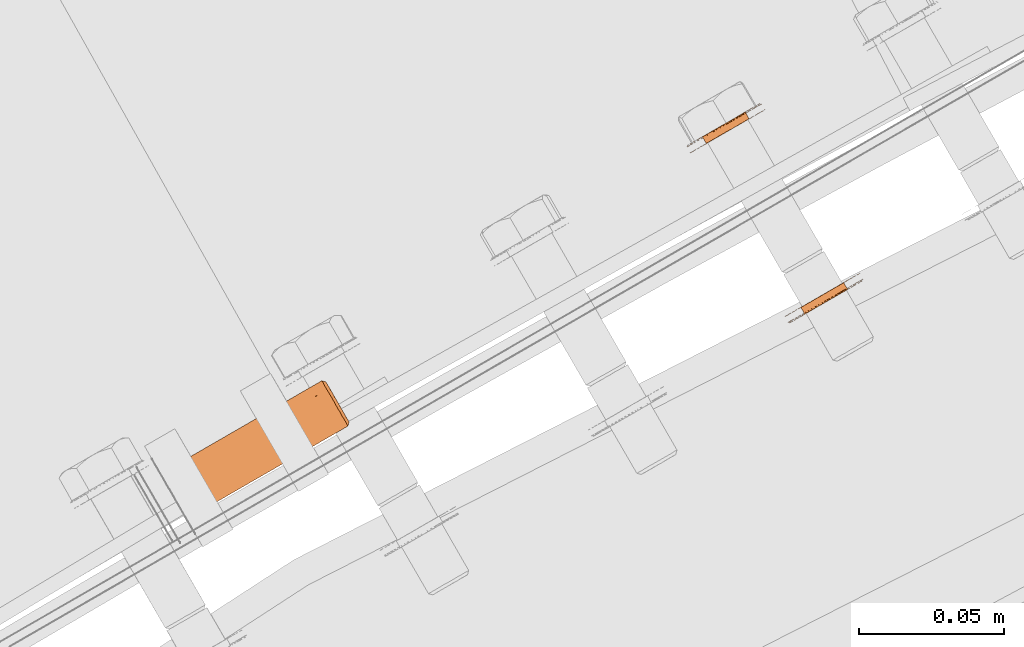
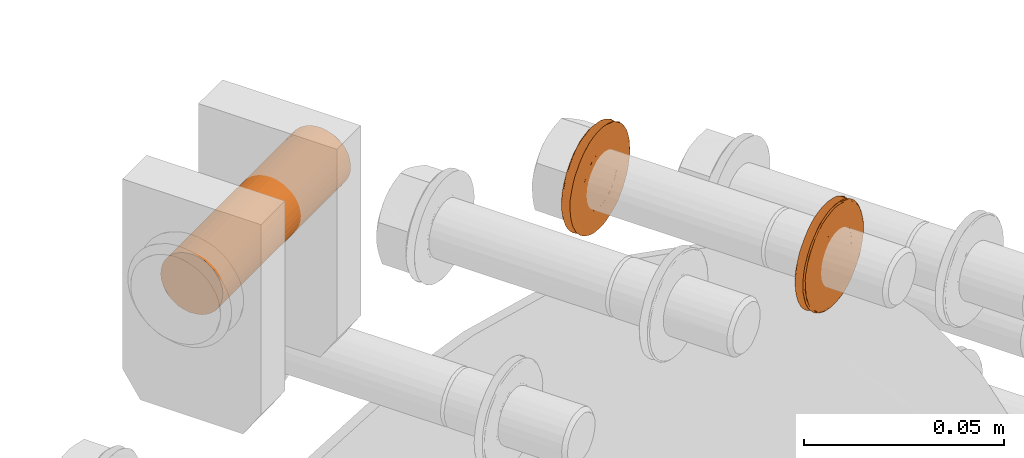
# One storey, part 118 of 126: 3 proxies.
"""IFC2X3 building model written with IfcOpenShell, lengths in millimetres."""

import ifcopenshell
import ifcopenshell.guid

model = None  # the IFC model being written
_history = None  # IfcOwnerHistory: only IFC2X3 demands one
_inside = {}  # id of a spatial element -> (the spatial element, [elements in it])
_under = {}  # id of a project, library or spatial element -> (it, [spatial elements below it])
_declared = {}  # id of a project -> (the project, [libraries it declares])
_typed = {}  # id of a type object -> (the type object, [elements of that type])
_made_of = {}  # id of a material, layer set ... -> (it, [elements and type objects made of it])


def new_model(schema):
    """Start an empty IFC model of exactly this schema.

    Asked for "IFC4X3", IfcOpenShell would pick the latest addendum, in which some entities
    have other attributes; the version numbers below select the first issue.
    IFC2X3 requires an IfcOwnerHistory on every rooted entity: one is made here for all.
    """
    global model, _history
    if schema == "IFC4X3":
        model = ifcopenshell.file(schema_version=(4, 3, 0, 0))
    else:
        model = ifcopenshell.file(schema=schema)
    _inside.clear()
    _under.clear()
    _declared.clear()
    _typed.clear()
    _made_of.clear()
    _history = None
    if model.schema == "IFC2X3":
        org = make("IfcOrganization", Name="unknown")
        user = make(
            "IfcPersonAndOrganization",
            ThePerson=make("IfcPerson", FamilyName="unknown"),
            TheOrganization=org,
        )
        app = make(
            "IfcApplication",
            ApplicationDeveloper=org,
            Version="unknown",
            ApplicationFullName="unknown",
            ApplicationIdentifier="unknown",
        )
        _history = make(
            "IfcOwnerHistory",
            OwningUser=user,
            OwningApplication=app,
            ChangeAction="ADDED",
            CreationDate=0,
        )
    return model


def make(cls, **values):
    """One entity of the class cls with the attributes given. An attribute that is None is left unset."""
    return model.create_entity(
        cls, **{name: value for name, value in values.items() if value is not None}
    )


def rooted(cls, **values):
    """An entity with a GlobalId (a new one), such as an element, a storey or a relation."""
    return make(cls, GlobalId=ifcopenshell.guid.new(), OwnerHistory=_history, **values)


def si_unit(unit_type, name, prefix=None):
    """IfcSIUnit, for example si_unit("LENGTHUNIT", "METRE", prefix="MILLI")."""
    return make("IfcSIUnit", UnitType=unit_type, Prefix=prefix, Name=name)


def assignment(units):
    """IfcUnitAssignment: the units of a project."""
    return None if units is None else make("IfcUnitAssignment", Units=units)


def point(xyz):
    """IfcCartesianPoint."""
    return None if xyz is None else make("IfcCartesianPoint", Coordinates=xyz)


def direction(xyz):
    """IfcDirection."""
    return None if xyz is None else make("IfcDirection", DirectionRatios=xyz)


def frame(location, z_axis=None, x_axis=None):
    """IfcAxis2Placement3D, a coordinate frame: its origin and axes. An axis left out is left unset."""
    return make(
        "IfcAxis2Placement3D",
        Location=point(location),
        Axis=direction(z_axis),
        RefDirection=direction(x_axis),
    )


def origin():
    """The frame at (0, 0, 0) with its axes left unset."""
    return frame((0.0, 0.0, 0.0))


def origin_with_axes():
    """The frame at (0, 0, 0) with the z axis (0, 0, 1) and the x axis (1, 0, 0) written out."""
    return frame((0.0, 0.0, 0.0), z_axis=(0.0, 0.0, 1.0), x_axis=(1.0, 0.0, 0.0))


def place(relative_to, where):
    """IfcLocalPlacement: puts the frame where relative to a parent placement (None: the world)."""
    return make(
        "IfcLocalPlacement", PlacementRelTo=relative_to, RelativePlacement=where
    )


def context(
    kind, dimensions, precision=None, world=None, true_north=None, identifier=None
):
    """IfcGeometricRepresentationContext, for example the 3D "Model" context."""
    return make(
        "IfcGeometricRepresentationContext",
        ContextIdentifier=identifier,
        ContextType=kind,
        CoordinateSpaceDimension=dimensions,
        Precision=precision,
        WorldCoordinateSystem=world,
        TrueNorth=true_north,
    )


def project(units=None, contexts=None):
    """IfcProject with its units and contexts."""
    return rooted(
        "IfcProject",
        Name="project",
        RepresentationContexts=contexts,
        UnitsInContext=assignment(units),
    )


def spatial(cls, under=None, at=None, **own):
    """A site, building, storey or space (cls), placed at a placement, below another one or the project."""
    s = rooted(cls, ObjectPlacement=at, **own)
    if under is not None:
        _under.setdefault(under.id(), (under, []))[1].append(s)
    return s


def faces_of(points, faces, orient=None, outer=None):
    """IfcFace entities. A face is a list of loops; a loop is a list of indices into points, from 0.

    orient and outer hold one flag for each loop. By default every Orientation is true, the
    first loop of a face is its IfcFaceOuterBound and the others are IfcFaceBound.
    """
    made = []
    for i, loops in enumerate(faces):
        bounds = []
        for j, loop in enumerate(loops):
            is_outer = j == 0 if outer is None else outer[i][j]
            bounds.append(
                make(
                    "IfcFaceOuterBound" if is_outer else "IfcFaceBound",
                    Bound=make("IfcPolyLoop", Polygon=[points[k] for k in loop]),
                    Orientation=True if orient is None else orient[i][j],
                )
            )
        made.append(make("IfcFace", Bounds=bounds))
    return made


def faceted_brep(points, faces, orient=None, outer=None, voids=None):
    """IfcFacetedBrep: a solid bounded by flat faces; with voids (closed shells), ...WithVoids."""
    shared = [point(p) for p in points]
    hull = make("IfcClosedShell", CfsFaces=faces_of(shared, faces, orient, outer))
    if voids is None:
        return make("IfcFacetedBrep", Outer=hull)
    return make(
        "IfcFacetedBrepWithVoids",
        Outer=hull,
        Voids=[
            make(cls, CfsFaces=faces_of(shared, fs, o, b)) for cls, fs, o, b in voids
        ],
    )


def shape(context_of_items, identifier, shape_type, items):
    """IfcShapeRepresentation: the items that make up one representation, for example the "Body"."""
    return make(
        "IfcShapeRepresentation",
        ContextOfItems=context_of_items,
        RepresentationIdentifier=identifier,
        RepresentationType=shape_type,
        Items=items,
    )


def material(Name=None, Category=None):
    """IfcMaterial."""
    return make("IfcMaterial", Name=Name, Category=Category)


def made_of(thing, what):
    """Note that an element or type object is made of a material, layer set ...; save() writes the relation."""
    if what is not None:
        _made_of.setdefault(what.id(), (what, []))[1].append(thing)
    return thing


def element(
    cls,
    number,
    at=None,
    inside=None,
    cuts=None,
    type_object=None,
    material=None,
    context=None,
    identifier="Body",
    shape_type=None,
    held_by="IfcProductDefinitionShape",
    body=None,
    shapes=None,
    **own,
):
    """One element of the class cls, such as IfcWall. Its Tag is "e" and its number.

    at: its placement. inside: the storey or other place that contains it. cuts: it is an
    opening in that element (IfcRelVoidsElement). A single representation is given by context,
    identifier, shape_type and body (its items); several are given by shapes. held_by: the class
    of the entity that holds the representations. save() writes the other relations.
    """
    e = rooted(cls, Tag="e%d" % number, ObjectPlacement=at, **own)
    if body is not None:
        shapes = [shape(context, identifier, shape_type, body)]
    if shapes is not None:
        e.Representation = make(held_by, Representations=shapes)
    if inside is not None:
        _inside.setdefault(inside.id(), (inside, []))[1].append(e)
    if cuts is not None:
        rooted(
            "IfcRelVoidsElement", RelatingBuildingElement=cuts, RelatedOpeningElement=e
        )
    if type_object is not None:
        _typed.setdefault(type_object.id(), (type_object, []))[1].append(e)
    return made_of(e, material)


def aggregate(whole, parts):
    """IfcRelAggregates: a whole, such as a stair, and the parts it consists of."""
    return rooted("IfcRelAggregates", RelatingObject=whole, RelatedObjects=parts)


def save(model, path):
    """Write the relations noted so far, then the file.

    IfcRelAggregates (storeys below a building ...), IfcRelContainedInSpatialStructure (elements
    in a storey), IfcRelDefinesByType, IfcRelAssociatesMaterial and IfcRelDeclares: one each for
    every whole, place, type object, material and project.
    """
    for whole, parts in _under.values():
        aggregate(whole, parts)
    for where, things in _inside.values():
        rooted(
            "IfcRelContainedInSpatialStructure",
            RelatedElements=things,
            RelatingStructure=where,
        )
    for kind, things in _typed.values():
        rooted("IfcRelDefinesByType", RelatedObjects=things, RelatingType=kind)
    for what, things in _made_of.values():
        rooted("IfcRelAssociatesMaterial", RelatedObjects=things, RelatingMaterial=what)
    for by, libraries in _declared.values():
        rooted("IfcRelDeclares", RelatingContext=by, RelatedDefinitions=libraries)
    model.write(path)


model = new_model("IFC2X3")

# Units and contexts
context_of_model_1 = context(None, 3, precision=0.1, world=origin())
context_of_model_2 = context(None, 3, precision=0.1, world=origin())
ifc_project = project(units=[si_unit("LENGTHUNIT", "METRE", prefix="MILLI"), si_unit("AREAUNIT", "SQUARE_METRE", prefix="CENTI"), si_unit("VOLUMEUNIT", "CUBIC_METRE", prefix="CENTI"), si_unit("MASSUNIT", "GRAM", prefix="KILO")], contexts=[context_of_model_1, context_of_model_2])

# Site, building, storey
site_placement = place(None, origin_with_axes())
site = spatial("IfcSite", under=ifc_project, at=site_placement, CompositionType="ELEMENT")
building_placement = place(site_placement, origin_with_axes())
building = spatial("IfcBuilding", under=site, at=building_placement, CompositionType="ELEMENT")
storey_placement = place(building_placement, origin_with_axes())
storey = spatial("IfcBuildingStorey", under=building, at=storey_placement, CompositionType="ELEMENT")

# Proxies
ifc_material = material(Name="STAHL")
proxy_1_placement = place(storey_placement, origin_with_axes())
element("IfcBuildingElementProxy", 1, at=proxy_1_placement, inside=storey, material=ifc_material, Name="profile", context=context_of_model_2, shape_type="Brep", body=[
    faceted_brep([(4189.1, 15005.2, 1270.8), (4187.8, 15007.6, 1270.8), (4187.3, 15007.3, 1271.8), (4188.6, 15004.9, 1271.8), (4189.7, 15005.6, 1269.8), (4188.4, 15007.9, 1269.8), (4190.5, 15006.0, 1268.9), (4189.1, 15008.3, 1268.9), (4191.3, 15006.5, 1268.2), (4190.0, 15008.8, 1268.2), (4198.6, 15010.7, 1282.9), (4197.2, 15013.0, 1282.9), (4198.1, 15013.5, 1282.3), (4199.5, 15011.2, 1282.3), (4197.6, 15010.1, 1283.3), (4196.2, 15012.4, 1283.3), (4196.6, 15009.5, 1283.6), (4195.2, 15011.9, 1283.6), (4195.5, 15008.9, 1283.7), (4194.2, 15011.2, 1283.7), (4194.5, 15008.3, 1283.7), (4193.1, 15010.6, 1283.7), (4193.4, 15007.7, 1283.4), (4192.1, 15010.0, 1283.4), (4192.5, 15007.1, 1283.0), (4191.1, 15009.5, 1283.0), (4191.5, 15006.6, 1282.5), (4190.2, 15008.9, 1282.5), (4190.7, 15006.1, 1281.7), (4189.3, 15008.4, 1281.7), (4189.9, 15005.7, 1280.9), (4188.6, 15008.0, 1280.9), (4189.3, 15005.3, 1279.9), (4187.9, 15007.6, 1279.9), (4188.8, 15005.0, 1278.9), (4187.4, 15007.3, 1278.9), (4188.4, 15004.8, 1277.8), (4187.0, 15007.1, 1277.8), (4188.1, 15004.6, 1276.6), (4186.8, 15007.0, 1276.6), (4188.0, 15004.6, 1275.4), (4186.7, 15006.9, 1275.4), (4188.1, 15004.6, 1274.2), (4186.7, 15007.0, 1274.2), (4188.3, 15004.7, 1273.0), (4186.9, 15007.1, 1273.0), (4182.2, 15001.7, 1274.6), (4182.2, 15001.7, 1276.2), (4182.4, 15001.8, 1277.8), (4182.7, 15002.0, 1279.3), (4183.1, 15002.2, 1280.8), (4183.7, 15002.5, 1282.2), (4184.4, 15002.9, 1283.6), (4185.2, 15003.4, 1284.8), (4186.1, 15003.9, 1286.0), (4187.2, 15004.5, 1287.0), (4188.3, 15005.2, 1287.9), (4189.4, 15005.9, 1288.7), (4190.7, 15006.6, 1289.3), (4192.0, 15007.3, 1289.8), (4193.3, 15008.1, 1290.1), (4194.7, 15008.9, 1290.2), (4196.0, 15009.7, 1290.2), (4197.4, 15010.4, 1290.0), (4198.7, 15011.2, 1289.7), (4200.0, 15012.0, 1289.2), (4201.2, 15012.7, 1288.5), (4202.4, 15013.3, 1287.7), (4203.5, 15014.0, 1286.8), (4204.5, 15014.6, 1285.7), (4205.4, 15015.1, 1284.5), (4206.2, 15015.5, 1283.2), (4206.8, 15015.9, 1281.9), (4207.4, 15016.2, 1280.4), (4207.8, 15016.4, 1278.9), (4208.0, 15016.6, 1277.4), (4208.2, 15016.7, 1275.8), (4208.2, 15016.7, 1274.2), (4208.0, 15016.6, 1272.7), (4207.7, 15016.4, 1271.2), (4207.3, 15016.1, 1269.7), (4206.7, 15015.8, 1268.2), (4206.0, 15015.4, 1266.9), (4205.2, 15014.9, 1265.6), (4204.3, 15014.4, 1264.5), (4203.2, 15013.8, 1263.4), (4202.1, 15013.2, 1262.5), (4200.9, 15012.5, 1261.8), (4199.7, 15011.8, 1261.2), (4198.4, 15011.0, 1260.7), (4197.1, 15010.3, 1260.4), (4195.7, 15009.5, 1260.2), (4194.3, 15008.7, 1260.3), (4193.0, 15007.9, 1260.4), (4191.7, 15007.1, 1260.8), (4190.4, 15006.4, 1261.3), (4189.1, 15005.7, 1262.0), (4188.0, 15005.0, 1262.8), (4186.9, 15004.4, 1263.7), (4185.9, 15003.8, 1264.8), (4185.0, 15003.3, 1265.9), (4184.2, 15002.8, 1267.2), (4183.5, 15002.5, 1268.6), (4183.0, 15002.1, 1270.0), (4182.6, 15001.9, 1271.5), (4182.3, 15001.8, 1273.1), (4181.1, 15003.7, 1274.6), (4181.2, 15003.7, 1273.1), (4181.5, 15003.9, 1271.5), (4181.9, 15004.1, 1270.0), (4182.4, 15004.4, 1268.6), (4183.1, 15004.8, 1267.2), (4183.8, 15005.3, 1265.9), (4184.7, 15005.8, 1264.8), (4185.7, 15006.4, 1263.7), (4186.8, 15007.0, 1262.8), (4188.0, 15007.7, 1262.0), (4189.2, 15008.4, 1261.3), (4190.5, 15009.1, 1260.8), (4191.8, 15009.9, 1260.4), (4193.2, 15010.7, 1260.3), (4194.6, 15011.5, 1260.2), (4195.9, 15012.2, 1260.4), (4197.2, 15013.0, 1260.7), (4198.5, 15013.8, 1261.2), (4199.8, 15014.5, 1261.8), (4201.0, 15015.2, 1262.5), (4202.1, 15015.8, 1263.4), (4203.1, 15016.4, 1264.5), (4204.0, 15016.9, 1265.6), (4204.8, 15017.4, 1266.9), (4205.5, 15017.8, 1268.2), (4206.1, 15018.1, 1269.7), (4206.5, 15018.4, 1271.2), (4206.8, 15018.6, 1272.7), (4207.0, 15018.7, 1274.2), (4207.0, 15018.7, 1275.8), (4206.9, 15018.6, 1277.4), (4206.6, 15018.4, 1278.9), (4206.2, 15018.2, 1280.4), (4205.7, 15017.9, 1281.9), (4205.0, 15017.5, 1283.2), (4204.2, 15017.1, 1284.5), (4203.3, 15016.5, 1285.7), (4202.4, 15016.0, 1286.8), (4201.3, 15015.3, 1287.7), (4200.1, 15014.7, 1288.5), (4198.9, 15014.0, 1289.2), (4197.6, 15013.2, 1289.7), (4196.2, 15012.4, 1290.0), (4194.9, 15011.7, 1290.2), (4193.5, 15010.9, 1290.2), (4192.2, 15010.1, 1290.1), (4190.8, 15009.3, 1289.8), (4189.5, 15008.6, 1289.3), (4188.3, 15007.9, 1288.7), (4187.1, 15007.2, 1287.9), (4186.0, 15006.5, 1287.0), (4185.0, 15005.9, 1286.0), (4184.1, 15005.4, 1284.8), (4183.2, 15004.9, 1283.6), (4182.5, 15004.5, 1282.2), (4182.0, 15004.2, 1280.8), (4181.5, 15004.0, 1279.3), (4181.2, 15003.8, 1277.8), (4181.1, 15003.7, 1276.2), (4182.8, 15001.5, 1275.1), (4182.8, 15001.6, 1276.7), (4183.0, 15001.7, 1278.3), (4183.4, 15001.9, 1279.8), (4183.9, 15002.2, 1281.3), (4184.5, 15002.6, 1282.7), (4185.3, 15003.0, 1284.0), (4186.2, 15003.5, 1285.2), (4187.1, 15004.1, 1286.3), (4188.2, 15004.7, 1287.3), (4189.4, 15005.4, 1288.1), (4190.6, 15006.1, 1288.8), (4191.9, 15006.8, 1289.3), (4193.3, 15007.6, 1289.6), (4194.6, 15008.4, 1289.8), (4196.0, 15009.2, 1289.8), (4197.4, 15010.0, 1289.6), (4198.7, 15010.7, 1289.3), (4200.0, 15011.5, 1288.8), (4201.2, 15012.2, 1288.2), (4202.4, 15012.9, 1287.4), (4203.5, 15013.5, 1286.4), (4204.5, 15014.1, 1285.3), (4205.4, 15014.6, 1284.1), (4206.2, 15015.1, 1282.8), (4206.8, 15015.4, 1281.4), (4207.3, 15015.7, 1280.0), (4207.7, 15016.0, 1278.5), (4208.0, 15016.1, 1276.9), (4208.0, 15016.1, 1275.3), (4208.0, 15016.1, 1273.7), (4207.8, 15016.0, 1272.2), (4207.4, 15015.8, 1270.7), (4206.9, 15015.5, 1269.2), (4206.3, 15015.1, 1267.8), (4205.5, 15014.7, 1266.5), (4204.6, 15014.2, 1265.3), (4203.6, 15013.6, 1264.2), (4202.6, 15013.0, 1263.2), (4201.4, 15012.3, 1262.4), (4200.2, 15011.6, 1261.7), (4198.9, 15010.8, 1261.2), (4197.5, 15010.1, 1260.8), (4196.2, 15009.3, 1260.7), (4194.8, 15008.5, 1260.6), (4193.4, 15007.7, 1260.8), (4192.1, 15006.9, 1261.1), (4190.8, 15006.2, 1261.6), (4189.5, 15005.5, 1262.3), (4188.4, 15004.8, 1263.1), (4187.3, 15004.1, 1264.0), (4186.3, 15003.6, 1265.1), (4185.4, 15003.1, 1266.3), (4184.6, 15002.6, 1267.6), (4184.0, 15002.2, 1269.0), (4183.4, 15001.9, 1270.5), (4183.1, 15001.7, 1272.0), (4182.8, 15001.6, 1273.5), (4196.3, 15009.4, 1266.8), (4195.3, 15008.8, 1266.7), (4194.2, 15008.2, 1266.8), (4193.2, 15007.6, 1267.1), (4192.2, 15007.0, 1267.6), (4200.3, 15011.7, 1281.5), (4201.0, 15012.1, 1280.7), (4201.7, 15012.4, 1279.7), (4202.1, 15012.7, 1278.6), (4202.5, 15012.9, 1277.5), (4202.7, 15013.0, 1276.3), (4202.8, 15013.1, 1275.1), (4202.7, 15013.0, 1273.9), (4202.4, 15012.9, 1272.7), (4202.0, 15012.7, 1271.6), (4201.5, 15012.4, 1270.5), (4200.9, 15012.0, 1269.5), (4200.1, 15011.6, 1268.7), (4199.3, 15011.1, 1268.0), (4198.3, 15010.5, 1267.4), (4197.3, 15010.0, 1267.0), (4199.0, 15014.0, 1281.5), (4190.9, 15009.3, 1267.6), (4191.8, 15009.9, 1267.1), (4192.9, 15010.5, 1266.8), (4193.9, 15011.1, 1266.7), (4195.0, 15011.7, 1266.8), (4196.0, 15012.3, 1267.0), (4197.0, 15012.9, 1267.4), (4197.9, 15013.4, 1268.0), (4198.8, 15013.9, 1268.7), (4199.5, 15014.3, 1269.5), (4200.2, 15014.7, 1270.5), (4200.7, 15015.0, 1271.6), (4201.1, 15015.2, 1272.7), (4201.3, 15015.4, 1273.9), (4201.4, 15015.4, 1275.1), (4201.3, 15015.4, 1276.3), (4201.1, 15015.3, 1277.5), (4200.8, 15015.1, 1278.6), (4200.3, 15014.8, 1279.7), (4199.7, 15014.4, 1280.7)], [[[0, 1, 2, 3]], [[4, 5, 1, 0]], [[6, 7, 5, 4]], [[6, 8, 9, 7]], [[10, 11, 12, 13]], [[14, 15, 11, 10]], [[16, 17, 15, 14]], [[18, 19, 17, 16]], [[20, 21, 19, 18]], [[22, 23, 21, 20]], [[24, 25, 23, 22]], [[26, 27, 25, 24]], [[28, 29, 27, 26]], [[30, 31, 29, 28]], [[32, 33, 31, 30]], [[34, 35, 33, 32]], [[36, 37, 35, 34]], [[38, 39, 37, 36]], [[40, 41, 39, 38]], [[42, 43, 41, 40]], [[44, 45, 43, 42]], [[3, 2, 45, 44]], [[46, 47, 48, 49, 50, 51, 52, 53, 54, 55, 56, 57, 58, 59, 60, 61, 62, 63, 64, 65, 66, 67, 68, 69, 70, 71, 72, 73, 74, 75, 76, 77, 78, 79, 80, 81, 82, 83, 84, 85, 86, 87, 88, 89, 90, 91, 92, 93, 94, 95, 96, 97, 98, 99, 100, 101, 102, 103, 104, 105, 46, 106, 107, 108, 109, 110, 111, 112, 113, 114, 115, 116, 117, 118, 119, 120, 121, 122, 123, 124, 125, 126, 127, 128, 129, 130, 131, 132, 133, 134, 135, 136, 137, 138, 139, 140, 141, 142, 143, 144, 145, 146, 147, 148, 149, 150, 151, 152, 153, 154, 155, 156, 157, 158, 159, 160, 161, 162, 163, 164, 165, 106]], [[166, 167, 168, 169, 170, 171, 172, 173, 174, 175, 176, 177, 178, 179, 180, 181, 182, 183, 184, 185, 186, 187, 188, 189, 190, 191, 192, 193, 194, 195, 196, 197, 198, 199, 200, 201, 202, 203, 204, 205, 206, 207, 89, 88, 87, 86, 85, 84, 83, 82, 81, 80, 79, 78, 77, 76, 75, 74, 73, 72, 71, 70, 69, 68, 67, 66, 65, 64, 63, 62, 61, 60, 59, 58, 57, 56, 55, 54, 53, 52, 51, 50, 49, 48, 47, 46, 105, 104, 103, 102, 101, 100, 99, 98, 97, 96, 95, 94, 93, 92, 91, 90, 89, 207, 208, 209, 210, 211, 212, 213, 214, 215, 216, 217, 218, 219, 220, 221, 222, 223]], [[166, 223, 222, 221, 220, 219, 218, 217, 216, 215, 214, 213, 212, 211, 210, 209, 208, 224, 225, 226, 227, 228, 8, 6, 4, 0, 3, 44, 42, 40, 38, 36, 34, 32, 30, 28, 26, 24, 22, 20, 18, 16, 14, 10, 13, 229, 230, 231, 232, 233, 234, 235, 236, 237, 238, 239, 240, 241, 242, 243, 244, 224, 208, 207, 206, 205, 204, 203, 202, 201, 200, 199, 198, 197, 196, 195, 194, 193, 192, 191, 190, 189, 188, 187, 186, 185, 184, 183, 182, 181, 180, 179, 178, 177, 176, 175, 174, 173, 172, 171, 170, 169, 168, 167]], [[13, 12, 245, 229]], [[8, 228, 246, 9]], [[228, 227, 247, 246]], [[227, 226, 248, 247]], [[226, 225, 249, 248]], [[225, 224, 250, 249]], [[224, 244, 251, 250]], [[244, 243, 252, 251]], [[243, 242, 253, 252]], [[242, 241, 254, 253]], [[241, 240, 255, 254]], [[240, 239, 256, 255]], [[239, 238, 257, 256]], [[238, 237, 258, 257]], [[237, 236, 259, 258]], [[236, 235, 260, 259]], [[235, 234, 261, 260]], [[234, 233, 262, 261]], [[233, 232, 263, 262]], [[232, 231, 264, 263]], [[231, 230, 265, 264]], [[230, 229, 245, 265]], [[106, 165, 164, 163, 162, 161, 160, 159, 158, 157, 156, 155, 154, 153, 152, 151, 150, 149, 148, 147, 146, 145, 144, 143, 142, 141, 140, 139, 138, 137, 136, 135, 134, 133, 132, 131, 130, 129, 128, 127, 126, 125, 124, 123, 122, 251, 252, 253, 254, 255, 256, 257, 258, 259, 260, 261, 262, 263, 264, 265, 245, 12, 11, 15, 17, 19, 21, 23, 25, 27, 29, 31, 33, 35, 37, 39, 41, 43, 45, 2, 1, 5, 7, 9, 246, 247, 248, 249, 250, 251, 122, 121, 120, 119, 118, 117, 116, 115, 114, 113, 112, 111, 110, 109, 108, 107]]]),
])
proxy_2_placement = place(storey_placement, origin_with_axes())
element("IfcBuildingElementProxy", 2, at=proxy_2_placement, inside=storey, material=ifc_material, Name="profile", context=context_of_model_2, shape_type="Brep", body=[
    faceted_brep([(4159.0, 15069.1, 1266.8), (4160.4, 15066.8, 1266.8), (4161.4, 15067.4, 1266.7), (4160.1, 15069.7, 1266.7), (4158.0, 15068.5, 1267.1), (4159.3, 15066.2, 1267.1), (4157.0, 15068.0, 1267.6), (4158.4, 15065.6, 1267.6), (4165.1, 15072.6, 1281.5), (4166.5, 15070.3, 1281.5), (4165.6, 15069.8, 1282.3), (4164.3, 15072.2, 1282.3), (4156.1, 15067.4, 1268.2), (4157.5, 15065.1, 1268.2), (4165.8, 15073.1, 1280.7), (4167.2, 15070.7, 1280.7), (4166.5, 15073.4, 1279.7), (4167.8, 15071.1, 1279.7), (4166.9, 15073.7, 1278.6), (4168.3, 15071.4, 1278.6), (4167.3, 15073.9, 1277.5), (4168.6, 15071.6, 1277.5), (4167.5, 15074.0, 1276.3), (4168.8, 15071.7, 1276.3), (4167.6, 15074.1, 1275.1), (4168.9, 15071.7, 1275.1), (4167.5, 15074.0, 1273.9), (4168.8, 15071.7, 1273.9), (4167.2, 15073.9, 1272.7), (4168.6, 15071.5, 1272.7), (4166.8, 15073.6, 1271.6), (4168.2, 15071.3, 1271.6), (4166.3, 15073.3, 1270.5), (4167.7, 15071.0, 1270.5), (4165.7, 15073.0, 1269.5), (4167.0, 15070.6, 1269.5), (4164.9, 15072.5, 1268.7), (4166.3, 15070.2, 1268.7), (4164.1, 15072.0, 1268.0), (4165.4, 15069.7, 1268.0), (4163.1, 15071.5, 1267.4), (4164.5, 15069.2, 1267.4), (4162.1, 15070.9, 1267.0), (4163.5, 15068.6, 1267.0), (4161.1, 15070.3, 1266.8), (4162.5, 15068.0, 1266.8), (4148.6, 15060.0, 1274.6), (4148.6, 15060.0, 1276.2), (4148.7, 15060.1, 1277.8), (4149.0, 15060.2, 1279.3), (4149.5, 15060.5, 1280.8), (4150.0, 15060.8, 1282.2), (4150.7, 15061.2, 1283.6), (4151.6, 15061.7, 1284.8), (4152.5, 15062.2, 1286.0), (4153.5, 15062.8, 1287.0), (4154.6, 15063.5, 1287.9), (4155.8, 15064.1, 1288.7), (4157.0, 15064.9, 1289.3), (4158.3, 15065.6, 1289.8), (4159.7, 15066.4, 1290.1), (4161.0, 15067.2, 1290.2), (4162.4, 15068.0, 1290.2), (4163.7, 15068.7, 1290.0), (4165.1, 15069.5, 1289.7), (4166.4, 15070.2, 1289.2), (4167.6, 15071.0, 1288.5), (4168.8, 15071.6, 1287.7), (4169.9, 15072.3, 1286.8), (4170.8, 15072.8, 1285.7), (4171.7, 15073.4, 1284.5), (4172.5, 15073.8, 1283.2), (4173.2, 15074.2, 1281.9), (4173.7, 15074.5, 1280.4), (4174.1, 15074.7, 1278.9), (4174.4, 15074.9, 1277.4), (4174.5, 15075.0, 1275.8), (4174.5, 15074.9, 1274.2), (4174.3, 15074.9, 1272.7), (4174.0, 15074.7, 1271.2), (4173.6, 15074.4, 1269.7), (4173.0, 15074.1, 1268.2), (4172.3, 15073.7, 1266.9), (4171.5, 15073.2, 1265.6), (4170.6, 15072.7, 1264.5), (4169.6, 15072.1, 1263.4), (4167.3, 15073.5, 1262.5), (4168.4, 15074.1, 1263.4), (4169.5, 15074.7, 1264.5), (4170.4, 15075.2, 1265.6), (4171.2, 15075.7, 1266.9), (4171.9, 15076.1, 1268.2), (4172.5, 15076.4, 1269.7), (4172.9, 15076.7, 1271.2), (4173.2, 15076.8, 1272.7), (4173.4, 15076.9, 1274.2), (4173.4, 15076.9, 1275.8), (4173.2, 15076.9, 1277.4), (4173.0, 15076.7, 1278.9), (4172.6, 15076.5, 1280.4), (4172.0, 15076.2, 1281.9), (4171.4, 15075.8, 1283.2), (4170.6, 15075.3, 1284.5), (4169.7, 15074.8, 1285.7), (4168.7, 15074.3, 1286.8), (4167.6, 15073.6, 1287.7), (4166.4, 15072.9, 1288.5), (4165.2, 15072.2, 1289.2), (4163.9, 15071.5, 1289.7), (4162.6, 15070.7, 1290.0), (4161.2, 15069.9, 1290.2), (4159.9, 15069.2, 1290.2), (4158.5, 15068.4, 1290.1), (4157.2, 15067.6, 1289.8), (4155.9, 15066.9, 1289.3), (4154.6, 15066.1, 1288.7), (4153.5, 15065.5, 1287.9), (4152.4, 15064.8, 1287.0), (4151.3, 15064.2, 1286.0), (4150.4, 15063.7, 1284.8), (4149.6, 15063.2, 1283.6), (4148.9, 15062.8, 1282.2), (4148.3, 15062.5, 1280.8), (4147.9, 15062.2, 1279.3), (4147.6, 15062.1, 1277.8), (4147.4, 15062.0, 1276.2), (4147.4, 15062.0, 1274.6), (4147.5, 15062.0, 1273.1), (4147.8, 15062.2, 1271.5), (4148.2, 15062.4, 1270.0), (4148.7, 15062.7, 1268.6), (4149.4, 15063.1, 1267.2), (4150.2, 15063.6, 1265.9), (4151.1, 15064.1, 1264.8), (4152.1, 15064.7, 1263.7), (4153.2, 15065.3, 1262.8), (4154.3, 15066.0, 1262.0), (4155.6, 15066.7, 1261.3), (4156.9, 15067.4, 1260.8), (4158.2, 15068.2, 1260.4), (4159.5, 15069.0, 1260.3), (4160.9, 15069.7, 1260.2), (4162.3, 15070.5, 1260.4), (4163.6, 15071.3, 1260.7), (4164.9, 15072.1, 1261.2), (4166.1, 15072.8, 1261.8), (4168.5, 15071.5, 1262.5), (4167.3, 15070.8, 1261.8), (4166.0, 15070.1, 1261.2), (4164.7, 15069.3, 1260.7), (4163.4, 15068.5, 1260.4), (4162.1, 15067.8, 1260.2), (4160.7, 15067.0, 1260.3), (4159.3, 15066.2, 1260.4), (4158.0, 15065.4, 1260.8), (4156.7, 15064.7, 1261.3), (4155.5, 15064.0, 1262.0), (4154.3, 15063.3, 1262.8), (4153.2, 15062.7, 1263.7), (4152.2, 15062.1, 1264.8), (4151.3, 15061.6, 1265.9), (4150.6, 15061.1, 1267.2), (4149.9, 15060.7, 1268.6), (4149.4, 15060.4, 1270.0), (4149.0, 15060.2, 1271.5), (4148.7, 15060.0, 1273.1), (4147.6, 15062.5, 1273.5), (4147.9, 15062.7, 1272.0), (4148.2, 15062.9, 1270.5), (4148.8, 15063.2, 1269.0), (4149.4, 15063.6, 1267.6), (4150.2, 15064.0, 1266.3), (4151.1, 15064.5, 1265.1), (4152.1, 15065.1, 1264.0), (4153.2, 15065.7, 1263.1), (4154.3, 15066.4, 1262.3), (4155.6, 15067.1, 1261.6), (4156.9, 15067.9, 1261.1), (4158.2, 15068.7, 1260.8), (4159.6, 15069.5, 1260.6), (4161.0, 15070.2, 1260.7), (4162.3, 15071.0, 1260.8), (4163.7, 15071.8, 1261.2), (4165.0, 15072.5, 1261.7), (4166.2, 15073.3, 1262.4), (4167.4, 15073.9, 1263.2), (4168.4, 15074.6, 1264.2), (4169.4, 15075.1, 1265.3), (4170.3, 15075.6, 1266.5), (4171.1, 15076.1, 1267.8), (4171.7, 15076.4, 1269.2), (4172.2, 15076.7, 1270.7), (4172.6, 15076.9, 1272.2), (4172.8, 15077.1, 1273.7), (4172.8, 15077.1, 1275.3), (4172.8, 15077.1, 1276.9), (4172.5, 15076.9, 1278.5), (4172.1, 15076.7, 1280.0), (4171.6, 15076.4, 1281.4), (4171.0, 15076.0, 1282.8), (4170.2, 15075.6, 1284.1), (4169.3, 15075.1, 1285.3), (4168.3, 15074.5, 1286.4), (4167.2, 15073.9, 1287.4), (4166.0, 15073.2, 1288.2), (4164.8, 15072.5, 1288.8), (4163.5, 15071.7, 1289.3), (4162.2, 15070.9, 1289.6), (4160.8, 15070.1, 1289.8), (4159.4, 15069.4, 1289.8), (4158.1, 15068.6, 1289.6), (4156.7, 15067.8, 1289.3), (4155.4, 15067.1, 1288.8), (4154.2, 15066.3, 1288.1), (4153.0, 15065.7, 1287.3), (4151.9, 15065.0, 1286.3), (4151.0, 15064.5, 1285.2), (4150.1, 15064.0, 1284.0), (4149.3, 15063.5, 1282.7), (4148.7, 15063.2, 1281.3), (4148.2, 15062.9, 1279.8), (4147.8, 15062.7, 1278.3), (4147.6, 15062.5, 1276.7), (4147.6, 15062.5, 1275.1), (4153.1, 15065.7, 1273.0), (4153.4, 15065.9, 1271.8), (4153.9, 15066.2, 1270.8), (4154.5, 15066.5, 1269.8), (4155.3, 15067.0, 1268.9), (4163.4, 15071.6, 1282.9), (4162.4, 15071.1, 1283.3), (4161.4, 15070.5, 1283.6), (4160.3, 15069.9, 1283.7), (4159.3, 15069.3, 1283.7), (4158.2, 15068.7, 1283.4), (4157.3, 15068.1, 1283.0), (4156.3, 15067.6, 1282.5), (4155.5, 15067.1, 1281.7), (4154.7, 15066.6, 1280.9), (4154.1, 15066.3, 1279.9), (4153.6, 15066.0, 1278.9), (4153.2, 15065.7, 1277.8), (4152.9, 15065.6, 1276.6), (4152.8, 15065.6, 1275.4), (4152.9, 15065.6, 1274.2), (4164.7, 15069.3, 1282.9), (4156.6, 15064.6, 1268.9), (4155.9, 15064.2, 1269.8), (4155.3, 15063.8, 1270.8), (4154.8, 15063.6, 1271.8), (4154.4, 15063.4, 1273.0), (4154.2, 15063.2, 1274.2), (4154.2, 15063.2, 1275.4), (4154.3, 15063.3, 1276.6), (4154.5, 15063.4, 1277.8), (4154.9, 15063.6, 1278.9), (4155.4, 15063.9, 1279.9), (4156.1, 15064.3, 1280.9), (4156.8, 15064.7, 1281.7), (4157.7, 15065.2, 1282.5), (4158.6, 15065.8, 1283.0), (4159.6, 15066.3, 1283.4), (4160.6, 15066.9, 1283.7), (4161.7, 15067.5, 1283.7), (4162.7, 15068.1, 1283.6), (4163.7, 15068.7, 1283.3)], [[[0, 1, 2, 3]], [[4, 5, 1, 0]], [[6, 7, 5, 4]], [[8, 9, 10, 11]], [[12, 13, 7, 6]], [[14, 15, 9, 8]], [[16, 17, 15, 14]], [[18, 19, 17, 16]], [[20, 21, 19, 18]], [[22, 23, 21, 20]], [[24, 25, 23, 22]], [[26, 27, 25, 24]], [[28, 29, 27, 26]], [[30, 31, 29, 28]], [[32, 33, 31, 30]], [[34, 35, 33, 32]], [[36, 37, 35, 34]], [[38, 39, 37, 36]], [[40, 41, 39, 38]], [[42, 43, 41, 40]], [[44, 45, 43, 42]], [[3, 2, 45, 44]], [[46, 47, 48, 49, 50, 51, 52, 53, 54, 55, 56, 57, 58, 59, 60, 61, 62, 63, 64, 65, 66, 67, 68, 69, 70, 71, 72, 73, 74, 75, 76, 77, 78, 79, 80, 81, 82, 83, 84, 85, 86, 87, 88, 89, 90, 91, 92, 93, 94, 95, 96, 97, 98, 99, 100, 101, 102, 103, 104, 105, 106, 107, 108, 109, 110, 111, 112, 113, 114, 115, 116, 117, 118, 119, 120, 121, 122, 123, 124, 125, 126, 127, 128, 129, 130, 131, 132, 133, 134, 135, 136, 137, 138, 139, 140, 141, 142, 143, 144, 145, 86, 85, 146, 147, 148, 149, 150, 151, 152, 153, 154, 155, 156, 157, 158, 159, 160, 161, 162, 163, 164, 165]], [[126, 125, 124, 123, 122, 121, 120, 119, 118, 117, 116, 115, 114, 113, 112, 111, 110, 109, 108, 107, 106, 105, 104, 103, 102, 101, 100, 99, 98, 97, 96, 95, 94, 93, 92, 91, 90, 89, 88, 87, 86, 145, 144, 143, 142, 141, 140, 139, 138, 137, 136, 135, 134, 133, 132, 131, 130, 129, 128, 127, 166, 167, 168, 169, 170, 171, 172, 173, 174, 175, 176, 177, 178, 179, 180, 181, 182, 183, 184, 185, 186, 187, 188, 189, 190, 191, 192, 193, 194, 195, 196, 197, 198, 199, 200, 201, 202, 203, 204, 205, 206, 207, 208, 209, 210, 211, 212, 213, 214, 215, 216, 217, 218, 219, 220, 221, 222, 223, 166, 127]], [[223, 222, 221, 220, 219, 218, 217, 216, 215, 214, 213, 212, 211, 210, 209, 208, 207, 206, 205, 204, 203, 202, 201, 200, 199, 198, 197, 196, 195, 194, 193, 192, 191, 190, 189, 188, 187, 186, 185, 184, 183, 182, 181, 180, 179, 178, 177, 176, 175, 174, 173, 172, 171, 170, 169, 168, 167, 224, 225, 226, 227, 228, 12, 6, 4, 0, 3, 44, 42, 40, 38, 36, 34, 32, 30, 28, 26, 24, 22, 20, 18, 16, 14, 8, 11, 229, 230, 231, 232, 233, 234, 235, 236, 237, 238, 239, 240, 241, 242, 243, 244, 224, 167, 166]], [[229, 11, 10, 245]], [[12, 228, 246, 13]], [[228, 227, 247, 246]], [[227, 226, 248, 247]], [[226, 225, 249, 248]], [[225, 224, 250, 249]], [[224, 244, 251, 250]], [[244, 243, 252, 251]], [[243, 242, 253, 252]], [[242, 241, 254, 253]], [[241, 240, 255, 254]], [[240, 239, 256, 255]], [[239, 238, 257, 256]], [[238, 237, 258, 257]], [[237, 236, 259, 258]], [[236, 235, 260, 259]], [[235, 234, 261, 260]], [[234, 233, 262, 261]], [[233, 232, 263, 262]], [[232, 231, 264, 263]], [[231, 230, 265, 264]], [[230, 229, 245, 265]], [[46, 165, 164, 251, 252, 253, 254, 255, 256, 257, 258, 259, 260, 261, 262, 263, 264, 265, 245, 10, 9, 15, 17, 19, 21, 23, 25, 27, 29, 31, 33, 35, 37, 39, 41, 43, 45, 2, 1, 5, 7, 13, 246, 247, 248, 249, 250, 251, 164, 163, 162, 161, 160, 159, 158, 157, 156, 155, 154, 153, 152, 151, 150, 149, 148, 147, 146, 85, 84, 83, 82, 81, 80, 79, 78, 77, 76, 75, 74, 73, 72, 71, 70, 69, 68, 67, 66, 65, 64, 63, 62, 61, 60, 59, 58, 57, 56, 55, 54, 53, 52, 51, 50, 49, 48, 47]]]),
])
proxy_3_placement = place(storey_placement, origin_with_axes())
element("IfcBuildingElementProxy", 3, at=proxy_3_placement, inside=storey, material=ifc_material, Name="profile", context=context_of_model_2, shape_type="Brep", body=[
    faceted_brep([(4024.9, 14965.2, 1380.8), (4024.7, 14965.4, 1380.5), (4018.1, 14976.9, 1391.9), (4018.1, 14976.8, 1392.0), (4018.3, 14976.7, 1392.2), (4018.5, 14976.5, 1392.5), (4025.2, 14965.0, 1381.2), (4018.9, 14976.4, 1392.7), (4025.6, 14964.9, 1381.5), (4019.2, 14976.3, 1392.9), (4019.6, 14976.3, 1393.1), (4020.0, 14976.4, 1393.2), (4020.4, 14976.6, 1393.2), (4026.9, 14965.2, 1382.0), (4026.4, 14965.0, 1381.9), (4026.0, 14964.9, 1381.7), (4020.7, 14976.8, 1393.2), (4027.3, 14965.4, 1382.0), (4021.0, 14977.0, 1393.2), (4027.7, 14965.7, 1381.9), (4021.3, 14977.4, 1393.0), (4027.9, 14966.1, 1381.7), (4021.5, 14977.7, 1392.9), (4021.6, 14978.0, 1392.7), (4021.6, 14978.4, 1392.4), (4028.3, 14966.8, 1381.2), (4028.2, 14966.4, 1381.5), (4021.6, 14978.7, 1392.2), (4028.3, 14967.1, 1380.8), (4021.5, 14978.9, 1391.9), (4028.2, 14967.4, 1380.5), (4028.8, 14966.6, 1381.1), (4028.0, 14967.7, 1380.1), (4027.7, 14967.8, 1379.8), (4027.3, 14967.9, 1379.5), (4026.9, 14967.9, 1379.2), (4027.0, 14967.9, 1378.8), (4027.4, 14967.9, 1378.9), (4027.7, 14967.9, 1379.1), (4028.1, 14967.8, 1379.3), (4028.4, 14967.7, 1379.6), (4028.6, 14967.5, 1379.8), (4028.8, 14967.3, 1380.1), (4028.9, 14967.1, 1380.4), (4028.9, 14966.9, 1380.7), (4028.6, 14966.2, 1381.4), (4028.2, 14965.8, 1381.7), (4027.8, 14965.4, 1381.9), (4026.5, 14964.6, 1381.9), (4027.2, 14965.0, 1382.0), (4027.0, 14964.9, 1382.0), (4026.8, 14964.8, 1382.0), (4026.1, 14964.5, 1381.7), (4025.1, 14964.4, 1381.1), (4025.7, 14964.4, 1381.6), (4025.4, 14964.4, 1381.3), (4024.8, 14964.5, 1380.8), (4024.6, 14964.6, 1380.5), (4024.5, 14964.8, 1380.1), (4024.4, 14965.0, 1380.0), (4024.3, 14965.1, 1379.8), (4024.3, 14965.4, 1379.5), (4024.4, 14965.8, 1379.3), (4024.5, 14966.1, 1379.1), (4024.7, 14966.4, 1378.9), (4024.9, 14966.7, 1378.8), (4024.9, 14966.8, 1379.2), (4024.7, 14966.4, 1379.5), (4024.6, 14966.0, 1379.8), (4024.6, 14965.7, 1380.1), (3973.7, 14937.4, 1393.3), (3974.3, 14936.3, 1392.3), (4029.8, 14968.3, 1392.3), (4029.1, 14969.4, 1393.3), (3973.0, 14938.7, 1394.2), (4028.4, 14970.7, 1394.2), (3975.3, 14934.6, 1383.0), (3975.0, 14935.2, 1381.5), (3974.5, 14936.0, 1380.1), (3973.9, 14937.0, 1379.0), (3973.2, 14938.2, 1378.1), (4028.7, 14970.2, 1378.1), (4029.3, 14969.0, 1379.0), (4029.9, 14968.0, 1380.1), (4026.6, 14967.8, 1378.7), (4026.2, 14967.7, 1378.7), (4025.8, 14967.5, 1378.6), (4025.5, 14967.3, 1378.7), (4025.2, 14967.0, 1378.7), (4030.4, 14967.2, 1381.5), (4030.8, 14966.6, 1383.0), (3972.2, 14940.0, 1394.7), (4027.6, 14972.0, 1394.7), (3971.4, 14941.4, 1395.0), (4026.8, 14973.4, 1395.0), (3970.5, 14942.9, 1394.9), (4026.0, 14974.9, 1394.9), (3969.7, 14944.3, 1394.6), (4025.2, 14976.3, 1394.6), (3969.0, 14945.6, 1393.9), (4024.4, 14977.6, 1393.9), (4018.0, 14977.2, 1391.5), (4017.9, 14977.4, 1391.2), (4018.0, 14977.7, 1390.9), (4018.2, 14978.0, 1390.7), (4018.4, 14978.3, 1390.4), (4018.7, 14978.5, 1390.3), (4018.9, 14978.7, 1390.2), (4019.2, 14978.9, 1390.2), (4019.6, 14979.1, 1390.2), (4020.0, 14979.2, 1390.3), (4020.3, 14979.3, 1390.5), (4020.7, 14979.4, 1390.8), (4021.0, 14979.3, 1391.0), (4021.2, 14979.2, 1391.3), (4021.4, 14979.1, 1391.6), (4023.7, 14978.8, 1393.0), (4023.1, 14979.8, 1391.9), (4022.6, 14980.7, 1390.5), (4022.3, 14981.3, 1389.0), (3966.9, 14949.3, 1389.0), (3967.2, 14948.7, 1390.5), (3967.7, 14947.8, 1391.9), (3968.3, 14946.8, 1393.0), (3975.5, 14934.2, 1384.6), (4031.0, 14966.2, 1384.6), (3975.6, 14934.1, 1386.3), (4031.0, 14966.1, 1386.3), (3975.5, 14934.3, 1387.9), (4030.9, 14966.3, 1387.9), (3975.2, 14934.7, 1389.5), (4030.7, 14966.7, 1389.5), (3974.9, 14935.4, 1391.0), (4030.3, 14967.4, 1391.0), (4030.4, 14969.2, 1380.8), (4030.9, 14968.4, 1382.1), (4031.2, 14967.8, 1383.5), (4031.4, 14967.5, 1385.0), (4031.4, 14967.5, 1386.6), (4031.2, 14967.8, 1388.2), (4031.0, 14968.2, 1389.6), (4030.5, 14969.0, 1390.9), (4030.0, 14969.9, 1392.1), (4029.4, 14971.0, 1393.0), (4028.6, 14972.3, 1393.6), (4027.9, 14973.6, 1393.9), (4027.1, 14975.0, 1394.0), (4026.3, 14976.3, 1393.7), (4025.6, 14977.6, 1393.1), (4024.9, 14978.7, 1392.3), (4024.4, 14979.7, 1391.2), (4023.9, 14980.5, 1389.9), (4023.6, 14981.0, 1388.5), (4022.1, 14981.6, 1387.4), (4023.4, 14981.3, 1387.0), (4027.9, 14971.6, 1377.4), (4027.1, 14973.0, 1377.1), (4026.2, 14974.4, 1377.0), (4025.4, 14975.8, 1377.3), (4024.6, 14977.2, 1377.8), (4023.9, 14978.4, 1378.7), (4023.3, 14979.5, 1379.7), (4022.8, 14980.4, 1381.0), (4022.4, 14981.1, 1382.5), (4022.1, 14981.5, 1384.1), (4022.0, 14981.7, 1385.7), (4023.4, 14981.3, 1385.4), (4023.5, 14981.1, 1383.8), (4023.8, 14980.6, 1382.4), (4024.2, 14979.9, 1381.1), (4024.8, 14978.9, 1379.9), (4025.4, 14977.8, 1379.0), (4026.1, 14976.6, 1378.4), (4026.9, 14975.2, 1378.1), (4027.7, 14973.9, 1378.0), (4028.5, 14972.5, 1378.3), (4029.2, 14971.3, 1378.9), (4029.9, 14970.1, 1379.7), (3969.2, 14945.2, 1377.8), (3970.0, 14943.8, 1377.3), (3970.8, 14942.4, 1377.0), (3971.7, 14941.0, 1377.1), (3972.5, 14939.6, 1377.4), (3966.7, 14949.6, 1387.4), (3966.6, 14949.7, 1385.7), (3966.7, 14949.5, 1384.1), (3967.0, 14949.1, 1382.5), (3967.3, 14948.4, 1381.0), (3967.9, 14947.5, 1379.7), (3968.5, 14946.4, 1378.7), (4025.2, 14967.1, 1379.1), (4025.6, 14967.4, 1379.0), (4026.4, 14967.8, 1379.1), (4026.0, 14967.7, 1379.0)], [[[0, 1, 2, 3, 4]], [[5, 6, 0, 4]], [[7, 8, 6, 5]], [[8, 7, 9, 10, 11, 12, 13, 14, 15]], [[12, 16, 17, 13]], [[18, 19, 17, 16]], [[20, 21, 19, 18]], [[21, 20, 22, 23, 24, 25, 26]], [[24, 27, 28, 25]], [[27, 29, 30, 28]], [[31, 25, 28, 30, 32, 33, 34, 35, 36, 37, 38, 39, 40, 41, 42, 43, 44]], [[45, 26, 25, 31]], [[21, 26, 45, 46]], [[19, 21, 46, 47]], [[17, 19, 47]], [[48, 14, 13, 17, 49, 50, 51]], [[49, 17, 47]], [[15, 14, 48, 52]], [[53, 6, 8, 15, 52, 54, 55]], [[53, 56, 57, 58, 59, 60, 61, 62, 63, 64, 65, 66, 67, 68, 69, 1, 0, 6]], [[70, 71, 72, 73]], [[74, 70, 73, 75]], [[76, 77, 78, 79, 80, 81, 82, 83, 43, 42, 41, 40, 39, 38, 37, 36, 84, 85, 86, 87, 88, 65, 64, 63, 62, 61, 60, 59, 58, 57, 56, 53, 55, 54, 52, 48, 51, 50, 49, 47, 46, 45, 31, 44, 43, 83, 89, 90]], [[91, 74, 75, 92]], [[93, 91, 92, 94]], [[95, 93, 94, 96]], [[97, 95, 96, 98]], [[99, 100, 16, 12, 11, 10, 9, 7, 5, 4, 3, 2, 101, 102, 103, 104, 105, 106, 107, 108, 109, 110, 111, 112, 113, 114, 115, 29, 27, 24, 23, 22, 20, 18, 16, 100, 116, 117, 118, 119, 120, 121, 122, 123]], [[99, 97, 98, 100]], [[124, 76, 90, 125]], [[126, 124, 125, 127]], [[128, 126, 127, 129]], [[130, 128, 129, 131]], [[132, 130, 131, 133]], [[71, 132, 133, 72]], [[89, 83, 134, 135]], [[90, 89, 135, 136]], [[125, 90, 136, 137]], [[127, 125, 137, 138, 139, 140, 141, 142, 143, 144, 145, 146, 147, 148, 149, 116, 100, 98, 96, 94, 92, 75, 73, 72, 133, 131, 129]], [[150, 117, 116, 149]], [[118, 117, 150, 151]], [[119, 118, 151, 152]], [[153, 119, 152, 154]], [[83, 82, 81, 155, 156, 157, 158, 159, 160, 161, 162, 163, 164, 165, 153, 154, 166, 167, 168, 169, 170, 171, 172, 173, 174, 175, 176, 177, 134]], [[178, 159, 158, 179]], [[180, 179, 158, 157]], [[181, 180, 157, 156]], [[182, 181, 156, 155]], [[120, 119, 153, 183]], [[80, 182, 155, 81]], [[183, 153, 165, 184]], [[184, 165, 164, 185]], [[185, 164, 163, 186]], [[186, 163, 162, 187]], [[187, 162, 161, 188]], [[188, 161, 160, 189]], [[189, 160, 159, 178]], [[138, 137, 136, 135, 134, 177, 176, 175, 174, 173, 172, 171, 170, 169, 168, 167, 166, 154, 152, 151, 150, 149, 148, 147, 146, 145, 144, 143, 142, 141, 140, 139]], [[65, 88, 190, 66]], [[87, 191, 190, 88]], [[87, 86, 85, 84, 192, 193, 191]], [[35, 192, 84, 36]], [[30, 29, 115, 114, 113, 33, 32]], [[113, 112, 34, 33]], [[111, 35, 34, 112]], [[110, 192, 35, 111]], [[191, 193, 192, 110, 109, 108, 107]], [[107, 106, 190, 191]], [[105, 66, 190, 106]], [[68, 67, 66, 105, 104, 103, 102]], [[102, 101, 69, 68]], [[101, 2, 1, 69]], [[126, 128, 130, 132, 71, 70, 74, 91, 93, 95, 97, 99, 123, 122, 121, 120, 183, 184, 185, 186, 187, 188, 189, 178, 179, 180, 181, 182, 80, 79, 78, 77, 76, 124]]]),
])

save(model, "model.ifc")
